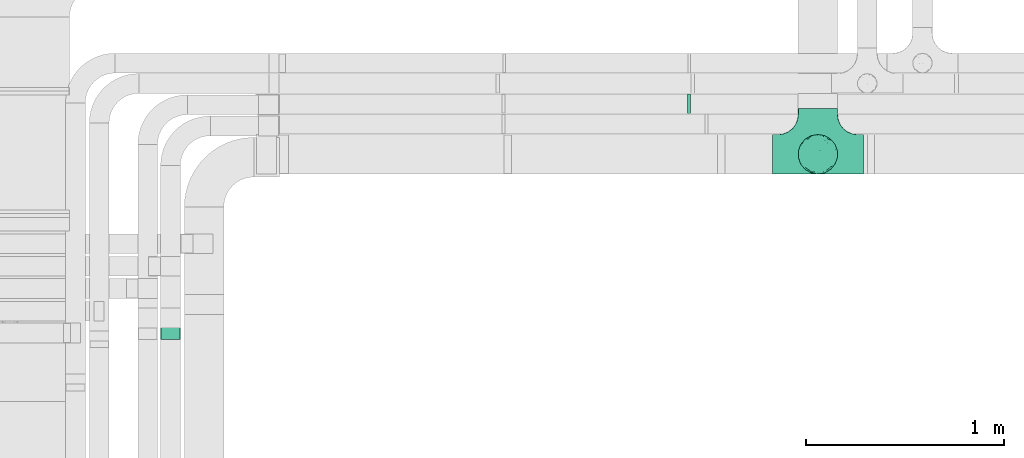
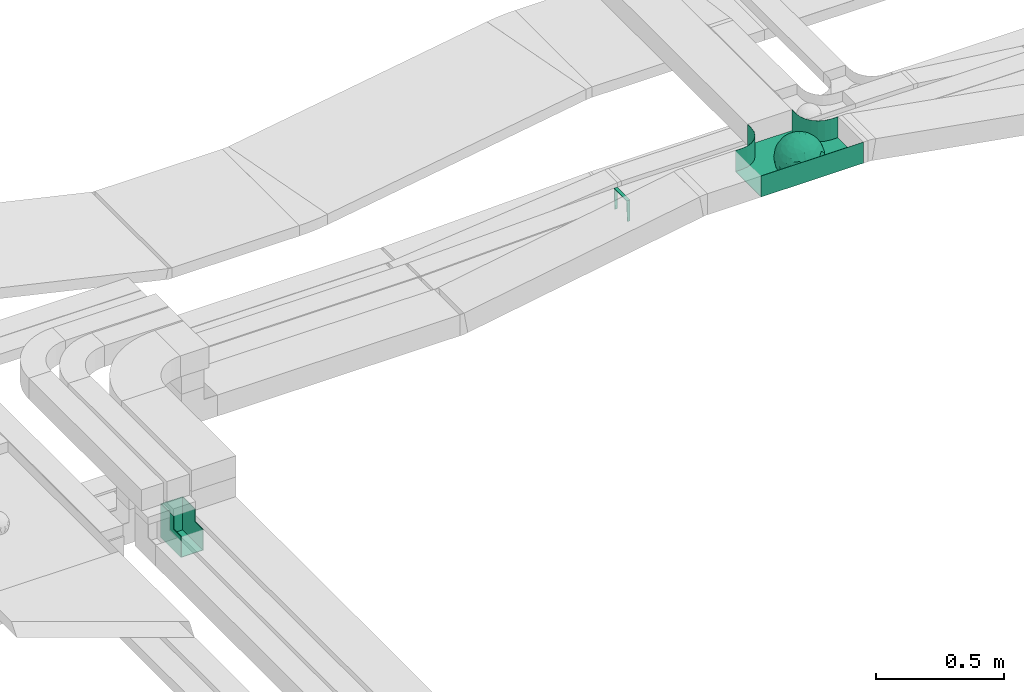
# One storey, part 26 of 28: 3 flow fittings.
"""IFC2X3 building model written with IfcOpenShell, lengths in millimetres."""

from ifc_helpers import new_model, entity, si_unit, converted_unit, derived_unit, direction, frame, origin, place, context, subcontext, project, spatial, faceted_brep, source, transform, mapped, material, material_list, type_object, type_shapes, element, save


model = new_model("IFC2X3")

# Units and contexts
model_context = context("Model", 3, precision=0.01, world=origin(), true_north=direction((6.12303176911189e-17, 1.0)))
body_context = subcontext(model_context, "Body", "Model", "MODEL_VIEW")
ifc_project = project(units=[si_unit("LENGTHUNIT", "METRE", prefix="MILLI"), si_unit("AREAUNIT", "SQUARE_METRE"), si_unit("VOLUMEUNIT", "CUBIC_METRE"), converted_unit("PLANEANGLEUNIT", "DEGREE", entity("IfcRatioMeasure", 0.0174532925199433), si_unit("PLANEANGLEUNIT", "RADIAN"), dimensions=[0, 0, 0, 0, 0, 0, 0]), si_unit("MASSUNIT", "GRAM", prefix="KILO"), derived_unit("MASSDENSITYUNIT", [(si_unit("MASSUNIT", "GRAM", prefix="KILO"), 1), (si_unit("LENGTHUNIT", "METRE"), -3)]), derived_unit("MOMENTOFINERTIAUNIT", [(si_unit("LENGTHUNIT", "METRE"), 4)]), si_unit("TIMEUNIT", "SECOND"), si_unit("FREQUENCYUNIT", "HERTZ"), si_unit("THERMODYNAMICTEMPERATUREUNIT", "DEGREE_CELSIUS"), derived_unit("THERMALTRANSMITTANCEUNIT", [(si_unit("MASSUNIT", "GRAM", prefix="KILO"), 1), (si_unit("THERMODYNAMICTEMPERATUREUNIT", "KELVIN"), -1), (si_unit("TIMEUNIT", "SECOND"), -3)]), derived_unit("VOLUMETRICFLOWRATEUNIT", [(si_unit("LENGTHUNIT", "METRE"), 3), (si_unit("TIMEUNIT", "SECOND"), -1)]), derived_unit("MASSFLOWRATEUNIT", [(si_unit("MASSUNIT", "GRAM", prefix="KILO"), 1), (si_unit("TIMEUNIT", "SECOND"), -1)]), derived_unit("ROTATIONALFREQUENCYUNIT", [(si_unit("TIMEUNIT", "SECOND"), -1)]), si_unit("ELECTRICCURRENTUNIT", "AMPERE"), si_unit("ELECTRICVOLTAGEUNIT", "VOLT"), si_unit("POWERUNIT", "WATT"), si_unit("FORCEUNIT", "NEWTON", prefix="KILO"), si_unit("ILLUMINANCEUNIT", "LUX"), si_unit("LUMINOUSFLUXUNIT", "LUMEN"), si_unit("LUMINOUSINTENSITYUNIT", "CANDELA"), derived_unit("USERDEFINED", [(si_unit("MASSUNIT", "GRAM", prefix="KILO"), -1), (si_unit("LENGTHUNIT", "METRE"), -2), (si_unit("TIMEUNIT", "SECOND"), 3), (si_unit("LUMINOUSFLUXUNIT", "LUMEN"), 1)]), derived_unit("LINEARVELOCITYUNIT", [(si_unit("LENGTHUNIT", "METRE"), 1), (si_unit("TIMEUNIT", "SECOND"), -1)]), si_unit("PRESSUREUNIT", "PASCAL"), derived_unit("USERDEFINED", [(si_unit("LENGTHUNIT", "METRE"), -2), (si_unit("MASSUNIT", "GRAM", prefix="KILO"), 1), (si_unit("TIMEUNIT", "SECOND"), -2)]), derived_unit("LINEARFORCEUNIT", [(si_unit("MASSUNIT", "GRAM", prefix="KILO"), 1), (si_unit("LENGTHUNIT", "METRE"), 1), (si_unit("TIMEUNIT", "SECOND"), -2), (si_unit("LENGTHUNIT", "METRE"), -1)]), derived_unit("PLANARFORCEUNIT", [(si_unit("MASSUNIT", "GRAM", prefix="KILO"), 1), (si_unit("LENGTHUNIT", "METRE"), 1), (si_unit("TIMEUNIT", "SECOND"), -2), (si_unit("LENGTHUNIT", "METRE"), -2)])], contexts=[model_context])

# Site, building, storey
site_placement = place(None, origin())
site = spatial("IfcSite", under=ifc_project, at=site_placement, CompositionType="ELEMENT")
building_placement = place(site_placement, origin())
building = spatial("IfcBuilding", under=site, at=building_placement, CompositionType="ELEMENT")
storey_placement = place(building_placement, frame((0.0, 0.0, 4200.0)))
storey = spatial("IfcBuildingStorey", under=building, at=storey_placement, CompositionType="ELEMENT", Elevation=4200.0)

# Flow fittings
ifc_material_1 = material()
ifc_material_2 = material()
ifc_material_list = material_list([ifc_material_1, ifc_material_2])
cable_carrier_fitting_type_1 = type_object("IfcCableCarrierFittingType", PredefinedType="NOTDEFINED", material=ifc_material_1)
shared_shape_1 = source(origin(), body_context, "Body", "Brep", [
    faceted_brep([(76.48, -37.8, -52.17), (89.29, -26.17, -36.65), (85.27, -46.63, -23.54), (-17.29, -34.78, -92.15), (0.0, -44.16, -89.72), (-24.64, -51.58, -82.05), (76.33, -15.08, -62.82), (55.58, -29.55, -77.71), (-17.1, 96.98, 0.0), (-18.67, 88.89, -41.84), (-33.9, 89.53, -28.9), (-45.46, -10.48, -88.45), (-19.82, 5.04, -97.89), (-23.66, -16.13, -95.81), (92.54, 33.68, 0.0), (85.28, 45.77, -25.16), (86.6, 50.0, 0.0), (49.24, -85.29, 0.0), (62.2, -72.19, -30.32), (64.28, -76.6, 0.0), (97.17, -8.72, -21.95), (90.76, 0.0, -41.98), (96.14, 14.4, -23.44), (98.48, 17.36, 0.0), (98.48, 0.0, 0.0), (79.01, 8.48, -60.71), (76.48, 37.8, -52.17), (87.7, 23.44, -41.95), (29.16, -37.6, -87.95), (20.3, -63.77, -74.31), (-69.62, 53.19, -48.2), (-47.21, 56.75, -67.46), (-61.6, 43.47, -65.69), (29.45, 71.32, -63.61), (47.21, 56.75, -67.46), (30.04, 49.65, -81.44), (-49.67, -77.09, -39.87), (-34.2, -93.97, 0.0), (-49.24, -85.29, 0.0), (61.4, 65.14, -44.57), (74.68, 59.14, -30.41), (61.95, 44.54, -64.64), (28.77, -89.42, -34.29), (34.2, -93.97, 0.0), (25.65, -95.48, 0.0), (17.1, -96.98, 0.0), (-64.28, -76.6, 0.0), (-75.44, -63.3, 0.0), (-74.75, -61.55, -24.99), (7.5, -83.69, -54.22), (36.49, -70.37, -60.97), (-76.48, -37.8, -52.17), (-87.07, -22.49, -43.74), (-79.06, -6.54, -60.88), (63.53, 0.0, -77.22), (-63.53, 0.0, -77.22), (-81.93, 16.04, -55.05), (-98.48, -17.36, 0.0), (-95.57, -17.05, -24.0), (-92.54, -33.68, 0.0), (65.86, 23.41, -71.51), (-19.3, 70.27, -68.49), (-44.33, 79.42, -41.56), (-76.48, 37.8, -52.17), (-45.05, 37.36, -81.09), (-67.2, 22.41, -70.59), (45.89, 15.54, -87.48), (-67.14, -22.46, -70.63), (-97.69, 5.09, -20.78), (-90.76, 0.0, -41.98), (-92.54, 33.68, 0.0), (-92.15, 27.2, -27.72), (28.87, 87.52, -38.83), (7.5, 83.69, -54.22), (1.23, 95.73, -28.9), (3.52, -95.84, -28.34), (-8.55, -98.49, 0.0), (-12.28, -96.15, -24.6), (75.44, 63.3, 0.0), (64.28, 76.6, 0.0), (75.44, -63.3, 0.0), (86.6, -50.0, 0.0), (-75.44, 63.3, 0.0), (-84.89, 46.81, -24.54), (-86.6, 50.0, 0.0), (-65.62, -61.39, -43.88), (-47.21, -56.75, -67.46), (-85.24, -44.68, -27.17), (46.02, 37.17, -80.63), (-63.18, 67.68, -37.79), (-7.15, -67.62, -73.33), (31.54, -5.3, -94.75), (9.85, -20.5, -97.38), (0.0, 13.3, -99.11), (49.35, -11.18, -86.25), (92.54, -33.68, 0.0), (98.48, -17.36, 0.0), (49.24, 85.29, 0.0), (46.4, 79.11, -39.86), (34.2, 93.97, 0.0), (-53.11, 15.12, -83.37), (64.53, -54.17, -53.86), (47.21, -56.75, -67.46), (22.89, 27.57, -93.36), (74.68, -59.14, -30.41), (46.4, -79.11, -39.86), (-15.74, 23.19, -95.99), (2.81, 33.98, -94.01), (9.21, 52.39, -84.68), (9.73, 69.75, -71.0), (17.1, 96.98, 0.0), (-5.62, -90.16, -42.88), (0.0, -100.0, 0.0), (-25.13, -93.37, -25.51), (-25.95, -84.88, -46.06), (-17.1, -96.98, 0.0), (-10.24, -80.78, -58.05), (-31.24, -69.76, -64.48), (-42.19, -33.64, -84.2), (-35.78, 18.55, -91.52), (-61.62, -43.52, -65.64), (-17.34, 40.89, -89.6), (-29.1, 55.69, -77.79), (-10.66, 57.03, -81.45), (-59.77, -75.57, -26.75), (-86.6, -50.0, 0.0), (-98.48, 0.0, 0.0), (-98.48, 17.36, 0.0), (-74.77, 60.7, -26.92), (-64.28, 76.6, 0.0), (-49.24, 85.29, 0.0), (-34.2, 93.97, 0.0), (0.0, 100.0, 0.0), (-76.48, -37.8, 52.17), (-89.29, -26.17, 36.65), (-85.27, -46.63, 23.54), (17.29, -34.78, 92.15), (0.0, -44.16, 89.72), (24.64, -51.58, 82.05), (-76.33, -15.08, 62.82), (-55.58, -29.55, 77.71), (18.67, 88.89, 41.84), (33.9, 89.53, 28.9), (17.34, 40.89, 89.6), (15.74, 23.19, 95.99), (35.78, 18.55, 91.52), (-85.28, 45.77, 25.16), (-62.2, -72.19, 30.32), (-97.17, -8.72, 21.95), (-96.14, 14.4, 23.44), (-79.01, 8.48, 60.71), (-76.48, 37.8, 52.17), (-87.7, 23.44, 41.95), (-29.16, -37.6, 87.95), (-20.3, -63.77, 74.31), (69.62, 53.19, 48.2), (47.21, 56.75, 67.46), (61.6, 43.47, 65.69), (-61.4, 65.14, 44.57), (49.27, -77.35, 39.88), (-74.68, 59.14, 30.41), (-61.95, 44.54, 64.64), (-7.5, -83.69, 54.22), (-36.49, -70.37, 60.97), (-28.77, -89.42, 34.29), (74.74, -61.65, 24.74), (3.0, -95.52, 29.45), (-13.47, -92.75, 34.88), (76.48, -37.8, 52.17), (87.07, -22.49, 43.74), (79.06, -6.54, 60.88), (-63.53, 0.0, 77.22), (63.53, 0.0, 77.22), (81.93, 16.04, 55.05), (95.57, -17.05, 24.0), (-65.86, 23.41, 71.51), (19.3, 70.27, 68.49), (44.33, 79.42, 41.56), (76.48, 37.8, 52.17), (45.05, 37.36, 81.09), (67.2, 22.41, 70.59), (-45.89, 15.54, 87.48), (67.14, -22.46, 70.63), (97.69, 5.09, 20.78), (90.76, 0.0, 41.98), (92.15, 27.2, 27.72), (-28.87, 87.52, 38.83), (-7.5, 83.69, 54.22), (-1.23, 95.73, 28.9), (7.15, -67.62, 73.33), (30.04, -71.02, 63.66), (-90.76, 0.0, 41.98), (84.89, 46.81, 24.54), (65.66, -61.85, 43.17), (47.21, -56.75, 67.46), (85.24, -44.68, 27.17), (-30.04, 49.65, 81.44), (-47.21, 56.75, 67.46), (-46.02, 37.17, 80.63), (63.18, 67.68, 37.79), (-31.54, -5.3, 94.75), (-9.85, -20.5, 97.38), (0.0, 13.3, 99.11), (-49.35, -11.18, 86.25), (-46.4, 79.11, 39.86), (-29.45, 71.32, 63.61), (24.31, -93.79, 24.74), (-64.53, -54.17, 53.86), (-47.21, -56.75, 67.46), (-22.89, 27.57, 93.36), (-46.4, -79.11, 39.86), (-74.68, -59.14, 30.41), (19.82, 5.04, 97.89), (-2.81, 33.98, 94.01), (-9.21, 52.39, 84.68), (-9.73, 69.75, 71.0), (9.65, -80.54, 58.49), (23.47, -86.31, 44.72), (35.11, -89.62, 27.11), (42.19, -33.64, 84.2), (23.66, -16.13, 95.81), (45.46, -10.48, 88.45), (61.62, -43.52, 65.64), (29.1, 55.69, 77.79), (10.66, 57.03, 81.45), (59.35, -75.82, 26.99), (74.77, 60.7, 26.92), (53.11, 15.12, 83.37)], [[[0, 1, 2]], [[3, 4, 5]], [[6, 0, 7]], [[8, 9, 10]], [[11, 12, 13]], [[14, 15, 16]], [[17, 18, 19]], [[20, 21, 22]], [[22, 23, 24]], [[25, 26, 27]], [[4, 28, 29]], [[30, 31, 32]], [[33, 34, 35]], [[36, 37, 38]], [[39, 40, 41]], [[42, 43, 44, 45]], [[46, 47, 48]], [[49, 50, 42]], [[51, 52, 53]], [[54, 25, 6]], [[55, 53, 56]], [[57, 58, 59]], [[26, 25, 60]], [[61, 31, 62]], [[32, 63, 30]], [[64, 65, 32]], [[54, 66, 60]], [[53, 67, 51]], [[58, 68, 69]], [[68, 70, 71]], [[72, 73, 74]], [[75, 76, 77]], [[6, 7, 54]], [[24, 20, 22]], [[78, 40, 79]], [[15, 26, 40]], [[1, 21, 20]], [[80, 2, 81]], [[63, 56, 71]], [[82, 83, 84]], [[36, 85, 86]], [[87, 58, 52]], [[35, 34, 88]], [[62, 31, 89]], [[42, 75, 49]], [[4, 29, 90]], [[91, 92, 93]], [[7, 94, 54]], [[6, 1, 0]], [[95, 81, 2]], [[24, 96, 20]], [[1, 20, 95]], [[1, 95, 2]], [[27, 22, 21]], [[15, 14, 22]], [[25, 27, 21]], [[15, 78, 16]], [[41, 40, 26]], [[40, 78, 15]], [[39, 97, 79]], [[97, 98, 99]], [[40, 39, 79]], [[33, 73, 72]], [[21, 1, 6]], [[25, 54, 60]], [[64, 100, 65]], [[26, 15, 27]], [[6, 25, 21]], [[0, 101, 7]], [[102, 28, 7]], [[92, 91, 28]], [[94, 28, 91]], [[88, 34, 41]], [[54, 94, 66]], [[41, 26, 60]], [[103, 91, 93]], [[88, 41, 60]], [[20, 96, 95]], [[101, 18, 102]], [[104, 80, 19]], [[101, 0, 104]], [[18, 105, 102]], [[43, 42, 105]], [[17, 43, 105]], [[29, 28, 102]], [[28, 4, 92]], [[105, 50, 102]], [[90, 29, 49]], [[88, 60, 66]], [[41, 34, 39]], [[34, 98, 39]], [[97, 39, 98]], [[103, 66, 91]], [[88, 66, 103]], [[12, 106, 93]], [[33, 98, 34]], [[107, 103, 93]], [[35, 103, 108]], [[103, 35, 88]], [[33, 109, 73]], [[109, 35, 108]], [[110, 72, 74]], [[72, 110, 99]], [[98, 33, 72]], [[99, 98, 72]], [[80, 104, 2]], [[0, 2, 104]], [[101, 104, 18]], [[7, 101, 102]], [[19, 18, 104]], [[105, 18, 17]], [[77, 111, 75]], [[75, 45, 112]], [[113, 114, 111]], [[115, 77, 76]], [[36, 114, 37]], [[90, 5, 4]], [[75, 42, 45]], [[50, 49, 29]], [[49, 116, 90]], [[5, 117, 86]], [[90, 116, 117]], [[118, 13, 3]], [[118, 5, 86]], [[11, 119, 12]], [[67, 120, 51]], [[11, 13, 118]], [[65, 55, 56]], [[121, 122, 123]], [[90, 117, 5]], [[51, 120, 85]], [[117, 36, 86]], [[36, 117, 114]], [[46, 48, 124]], [[38, 124, 36]], [[85, 124, 48]], [[87, 125, 59]], [[125, 87, 47]], [[48, 51, 85]], [[68, 57, 126, 127]], [[59, 58, 87]], [[58, 69, 52]], [[53, 52, 69]], [[87, 52, 51]], [[56, 53, 69]], [[53, 55, 67]], [[71, 56, 69]], [[56, 63, 65]], [[71, 69, 68]], [[128, 129, 89]], [[11, 67, 55]], [[120, 118, 86]], [[32, 65, 63]], [[100, 55, 65]], [[118, 120, 67]], [[85, 120, 86]], [[129, 128, 82]], [[64, 32, 31]], [[62, 130, 131]], [[130, 62, 89]], [[9, 73, 61]], [[10, 62, 131]], [[109, 61, 73]], [[73, 9, 74]], [[64, 121, 119]], [[122, 61, 123]], [[64, 119, 100]], [[64, 31, 122]], [[107, 108, 103]], [[47, 87, 48]], [[51, 48, 87]], [[57, 68, 58]], [[64, 122, 121]], [[89, 129, 130]], [[67, 11, 118]], [[11, 55, 100]], [[82, 128, 83]], [[30, 128, 89]], [[83, 63, 71]], [[63, 83, 128]], [[84, 83, 71]], [[10, 61, 62]], [[74, 8, 132]], [[8, 74, 9]], [[110, 74, 132]], [[3, 92, 4]], [[92, 13, 12]], [[22, 27, 15]], [[14, 23, 22]], [[11, 100, 119]], [[128, 30, 63]], [[31, 30, 89]], [[28, 94, 7]], [[66, 94, 91]], [[42, 50, 105]], [[29, 102, 50]], [[106, 107, 93]], [[123, 107, 121]], [[35, 109, 33]], [[109, 108, 123]], [[75, 112, 76]], [[113, 77, 115]], [[114, 116, 111]], [[115, 37, 113]], [[37, 114, 113]], [[49, 75, 111]], [[117, 116, 114]], [[111, 77, 113]], [[49, 111, 116]], [[118, 3, 5]], [[92, 3, 13]], [[106, 119, 121]], [[92, 12, 93]], [[119, 106, 12]], [[107, 106, 121]], [[46, 124, 38]], [[85, 36, 124]], [[70, 68, 127]], [[70, 84, 71]], [[31, 61, 122]], [[109, 123, 61]], [[107, 123, 108]], [[8, 10, 131]], [[61, 10, 9]], [[133, 134, 135]], [[136, 137, 138]], [[139, 133, 140]], [[110, 141, 142]], [[143, 144, 145]], [[70, 146, 84]], [[38, 147, 46]], [[126, 57, 148]], [[149, 127, 126]], [[150, 151, 152]], [[137, 153, 154]], [[155, 156, 157]], [[130, 129, 158]], [[159, 43, 17]], [[158, 160, 161]], [[162, 163, 164]], [[19, 80, 165]], [[166, 167, 115]], [[168, 169, 170]], [[171, 150, 139]], [[172, 170, 173]], [[96, 174, 95]], [[151, 150, 175]], [[176, 156, 177]], [[157, 178, 155]], [[179, 180, 157]], [[171, 181, 175]], [[170, 182, 168]], [[174, 183, 184]], [[185, 23, 14, 16]], [[186, 187, 188]], [[138, 189, 190]], [[139, 140, 171]], [[126, 148, 149]], [[82, 160, 129]], [[146, 151, 160]], [[134, 191, 148]], [[47, 135, 125]], [[178, 173, 185]], [[78, 192, 16]], [[159, 193, 194]], [[195, 174, 169]], [[196, 197, 198]], [[177, 156, 199]], [[166, 112, 45]], [[154, 189, 137]], [[200, 201, 202]], [[140, 203, 171]], [[191, 149, 148]], [[59, 125, 135]], [[133, 139, 134]], [[134, 148, 59]], [[134, 59, 135]], [[152, 149, 191]], [[146, 70, 149]], [[150, 152, 191]], [[146, 82, 84]], [[161, 160, 151]], [[160, 82, 146]], [[204, 131, 130]], [[186, 205, 187]], [[160, 158, 129]], [[197, 196, 205]], [[191, 134, 139]], [[150, 171, 175]], [[45, 206, 166]], [[151, 146, 152]], [[139, 150, 191]], [[133, 207, 140]], [[208, 153, 140]], [[201, 200, 153]], [[203, 153, 200]], [[198, 197, 161]], [[171, 203, 181]], [[161, 151, 175]], [[209, 200, 202]], [[198, 161, 175]], [[148, 57, 59]], [[38, 37, 210]], [[211, 47, 46]], [[207, 133, 211]], [[147, 210, 208]], [[210, 37, 164]], [[208, 207, 147]], [[154, 153, 208]], [[153, 137, 201]], [[210, 163, 208]], [[189, 154, 162]], [[198, 175, 181]], [[161, 197, 158]], [[197, 204, 158]], [[130, 158, 204]], [[209, 181, 200]], [[198, 181, 209]], [[212, 144, 202]], [[205, 204, 197]], [[213, 209, 202]], [[196, 209, 214]], [[209, 196, 198]], [[205, 215, 187]], [[215, 196, 214]], [[8, 186, 188]], [[186, 8, 131]], [[204, 205, 186]], [[131, 204, 186]], [[47, 211, 135]], [[133, 135, 211]], [[207, 211, 147]], [[140, 207, 208]], [[46, 147, 211]], [[210, 147, 38]], [[166, 115, 76, 112]], [[115, 164, 37]], [[163, 162, 154]], [[216, 166, 217]], [[138, 137, 189]], [[162, 216, 189]], [[218, 44, 43]], [[44, 218, 206]], [[189, 216, 190]], [[219, 220, 136]], [[219, 138, 194]], [[221, 145, 212]], [[182, 222, 168]], [[221, 220, 219]], [[180, 172, 173]], [[143, 223, 224]], [[168, 222, 193]], [[194, 138, 190]], [[190, 159, 194]], [[190, 217, 218]], [[19, 165, 225]], [[17, 225, 159]], [[193, 225, 165]], [[195, 81, 95]], [[81, 195, 80]], [[165, 168, 193]], [[183, 96, 24, 23]], [[95, 174, 195]], [[174, 184, 169]], [[170, 169, 184]], [[195, 169, 168]], [[173, 170, 184]], [[170, 172, 182]], [[185, 173, 184]], [[173, 178, 180]], [[185, 184, 183]], [[226, 79, 199]], [[221, 182, 172]], [[222, 219, 194]], [[157, 180, 178]], [[227, 172, 180]], [[219, 222, 182]], [[193, 222, 194]], [[79, 226, 78]], [[179, 157, 156]], [[177, 97, 99]], [[97, 177, 199]], [[141, 187, 176]], [[142, 177, 99]], [[215, 176, 187]], [[187, 141, 188]], [[179, 143, 145]], [[223, 176, 224]], [[179, 145, 227]], [[179, 156, 223]], [[213, 214, 209]], [[96, 183, 174]], [[185, 183, 23]], [[80, 195, 165]], [[168, 165, 195]], [[199, 79, 97]], [[182, 221, 219]], [[221, 172, 227]], [[78, 226, 192]], [[155, 226, 199]], [[192, 178, 185]], [[178, 192, 226]], [[16, 192, 185]], [[142, 176, 177]], [[188, 110, 132]], [[110, 188, 141]], [[8, 188, 132]], [[136, 201, 137]], [[201, 220, 212]], [[149, 152, 146]], [[70, 127, 149]], [[167, 162, 164]], [[179, 227, 180]], [[221, 227, 145]], [[226, 155, 178]], [[156, 155, 199]], [[153, 203, 140]], [[181, 203, 200]], [[164, 163, 210]], [[154, 208, 163]], [[144, 213, 202]], [[224, 213, 143]], [[196, 215, 205]], [[215, 214, 224]], [[166, 216, 162]], [[190, 216, 217]], [[218, 217, 206]], [[43, 159, 218]], [[190, 218, 159]], [[166, 206, 217]], [[44, 206, 45]], [[219, 136, 138]], [[201, 136, 220]], [[201, 212, 202]], [[221, 212, 220]], [[145, 144, 212]], [[213, 144, 143]], [[19, 225, 17]], [[193, 159, 225]], [[179, 223, 143]], [[156, 176, 223]], [[215, 224, 176]], [[213, 224, 214]], [[110, 142, 99]], [[176, 142, 141]], [[115, 167, 164]], [[166, 162, 167]]]),
    faceted_brep([(-103.41, -174.12, 50.0), (-100.0, -200.0, 50.0), (-100.0, -230.0, 50.0), (-99.2, -230.0, 50.0), (-99.2, -200.0, 50.0), (-102.63, -173.91, 50.0), (-112.7, -149.6, 50.0), (-128.72, -128.72, 50.0), (-149.6, -112.7, 50.0), (-173.91, -102.63, 50.0), (-200.0, -99.2, 50.0), (-230.0, -99.2, 50.0), (-230.0, -100.0, 50.0), (-200.0, -100.0, 50.0), (-174.12, -103.41, 50.0), (-150.0, -113.4, 50.0), (-129.29, -129.29, 50.0), (-113.4, -150.0, 50.0), (230.0, -100.0, 50.0), (230.0, -99.2, 50.0), (200.0, -99.2, 50.0), (173.91, -102.63, 50.0), (149.6, -112.7, 50.0), (128.72, -128.72, 50.0), (112.7, -149.6, 50.0), (102.63, -173.91, 50.0), (99.2, -200.0, 50.0), (99.2, -230.0, 50.0), (100.0, -230.0, 50.0), (100.0, -200.0, 50.0), (103.41, -174.12, 50.0), (113.4, -150.0, 50.0), (129.29, -129.29, 50.0), (150.0, -113.4, 50.0), (174.12, -103.41, 50.0), (200.0, -100.0, 50.0), (230.0, 99.2, 50.0), (230.0, 100.0, 50.0), (-230.0, 100.0, 50.0), (-230.0, 99.2, 50.0), (-230.0, -100.0, -50.0), (-230.0, 100.0, -50.0), (230.0, 100.0, -50.0), (230.0, -100.0, -50.0), (200.0, -100.0, -50.0), (174.12, -103.41, -50.0), (150.0, -113.4, -50.0), (129.29, -129.29, -50.0), (113.4, -150.0, -50.0), (103.41, -174.12, -50.0), (100.0, -200.0, -50.0), (100.0, -230.0, -50.0), (-100.0, -230.0, -50.0), (-100.0, -200.0, -50.0), (-103.41, -174.12, -50.0), (-113.4, -150.0, -50.0), (-129.29, -129.29, -50.0), (-150.0, -113.4, -50.0), (-174.12, -103.41, -50.0), (-200.0, -100.0, -50.0), (-100.0, -200.0, -49.2), (99.2, -230.0, -49.2), (-99.2, -230.0, -49.2), (-99.2, -200.0, -49.2), (-200.0, -99.2, -49.2), (-230.0, -99.2, -49.2), (230.0, -99.2, -49.2), (200.0, -99.2, -49.2), (-230.0, 99.2, -49.2), (-200.0, -100.0, -49.2), (200.0, -100.0, -49.2), (230.0, 99.2, -49.2), (99.2, -200.0, -49.2), (100.0, -200.0, -49.2), (-173.91, -102.63, -49.2), (-149.6, -112.7, -49.2), (-128.72, -128.72, -49.2), (-112.7, -149.6, -49.2), (-102.63, -173.91, -49.2), (102.63, -173.91, -49.2), (112.7, -149.6, -49.2), (128.72, -128.72, -49.2), (149.6, -112.7, -49.2), (173.91, -102.63, -49.2)], [[[0, 1, 2, 3, 4, 5, 6, 7, 8, 9, 10, 11, 12, 13, 14, 15, 16, 17]], [[18, 19, 20, 21, 22, 23, 24, 25, 26, 27, 28, 29, 30, 31, 32, 33, 34, 35]], [[36, 37, 38, 39]], [[40, 41, 42, 43, 44, 45, 46, 47, 48, 49, 50, 51, 52, 53, 54, 55, 56, 57, 58, 59]], [[2, 1, 60, 53, 52]], [[3, 2, 52, 51, 28, 27, 61, 62]], [[4, 3, 62, 63]], [[11, 10, 64, 65]], [[20, 19, 66, 67]], [[39, 38, 41, 40, 12, 11, 65, 68]], [[13, 12, 40, 59, 69]], [[18, 35, 70, 44, 43]], [[19, 18, 43, 42, 37, 36, 71, 66]], [[27, 26, 72, 61]], [[29, 28, 51, 50, 73]], [[38, 37, 42, 41]], [[36, 39, 68, 71]], [[68, 65, 64, 74, 75, 76, 77, 78, 63, 62, 61, 72, 79, 80, 81, 82, 83, 67, 66, 71]], [[14, 13, 69, 59, 58]], [[15, 14, 58, 57]], [[57, 56, 16, 15]], [[17, 16, 56, 55]], [[0, 17, 55, 54]], [[1, 0, 54, 53, 60]], [[5, 78, 77, 6]], [[6, 77, 76, 7]], [[63, 78, 5, 4]], [[8, 75, 74, 9]], [[9, 74, 64, 10]], [[7, 76, 75, 8]], [[21, 83, 82, 22]], [[22, 82, 81, 23]], [[67, 83, 21, 20]], [[24, 80, 79, 25]], [[25, 79, 72, 26]], [[23, 81, 80, 24]], [[30, 29, 73, 50, 49]], [[31, 30, 49, 48]], [[32, 31, 48, 47]], [[34, 33, 46, 45]], [[34, 45, 44, 70, 35]], [[46, 33, 32, 47]]]),
])
type_shapes(cable_carrier_fitting_type_1, [shared_shape_1])
flow_fitting_1_placement = place(storey_placement, frame((14583.54, 11543.79, 2954.06), z_axis=(0.0, 0.0, 1.0), x_axis=(-1.0, 0.0, 0.0)))
element("IfcFlowFitting", 1, at=flow_fitting_1_placement, inside=storey, type_object=cable_carrier_fitting_type_1, material=ifc_material_list, Name="470_DKC_S5_T", context=body_context, shape_type="MappedRepresentation", body=[
    mapped(shared_shape_1, transform((0.0, 0.0, 0.0), scale=1.0)),
])
cable_carrier_fitting_type_2 = type_object("IfcCableCarrierFittingType", PredefinedType="NOTDEFINED", material=ifc_material_2)
shared_shape_2 = source(origin(), body_context, "Body", "Brep", [
    faceted_brep([(-6.77, -50.0, 50.0), (-6.77, 50.0, 50.0), (-6.77, 50.0, 47.46), (-6.77, -47.46, 47.46), (-6.77, -47.46, -47.46), (-6.77, 50.0, -47.46), (-6.77, 50.0, -50.0), (-6.77, -50.0, -50.0), (8.46, -49.74, 50.0), (8.46, -49.74, -50.0), (5.08, 50.2, -50.0), (5.08, 50.2, -47.46), (8.37, -47.2, -47.46), (8.37, -47.2, 47.46), (5.08, 50.2, 47.46), (5.08, 50.2, 50.0), (0.85, -50.0, 50.0), (-0.85, 50.0, 50.0), (-0.85, 50.0, 47.46), (0.8, -47.46, 47.46), (0.8, -47.46, -47.46), (-0.85, 50.0, -47.46), (-0.85, 50.0, -50.0), (0.85, -50.0, -50.0)], [[[0, 1, 2, 3, 4, 5, 6, 7]], [[8, 9, 10, 11, 12, 13, 14, 15]], [[1, 0, 16, 8, 15, 17]], [[2, 1, 17, 18]], [[3, 2, 18, 14, 13, 19]], [[4, 3, 19, 20]], [[5, 4, 20, 12, 11, 21]], [[6, 5, 21, 22]], [[7, 6, 22, 10, 9, 23]], [[0, 7, 23, 16]], [[18, 17, 15, 14]], [[20, 19, 13, 12]], [[22, 21, 11, 10]], [[16, 23, 9, 8]]]),
])
type_shapes(cable_carrier_fitting_type_2, [shared_shape_2])
flow_fitting_2_placement = place(storey_placement, frame((13934.02, 11798.96, 2800.18), z_axis=(0.0, 1.0, 0.0), x_axis=(0.999429384266034, 0.0, 0.0337772980804678)))
element("IfcFlowFitting", 2, at=flow_fitting_2_placement, inside=storey, type_object=cable_carrier_fitting_type_2, material=ifc_material_2, context=body_context, shape_type="MappedRepresentation", body=[
    mapped(shared_shape_2, transform((0.0, 0.0, 0.0), scale=1.0)),
])
cable_carrier_fitting_type_3 = type_object("IfcCableCarrierFittingType", PredefinedType="NOTDEFINED", material=ifc_material_2)
shared_shape_3 = source(origin(), body_context, "Body", "Brep", [
    faceted_brep([(-110.01, -50.0, 50.0), (-110.01, 50.0, 50.0), (-110.01, 50.0, 47.46), (-110.01, -47.46, 47.46), (-110.01, -47.46, -47.46), (-110.01, 50.0, -47.46), (-110.01, 50.0, -50.0), (-110.01, -50.0, -50.0), (49.99, 110.02, 50.0), (49.99, 110.02, -50.0), (-50.01, 110.01, -50.0), (-50.01, 110.01, -47.46), (47.45, 110.01, -47.46), (47.45, 110.01, 47.46), (-50.01, 110.01, 47.46), (-50.01, 110.01, 50.0), (50.0, -50.0, 50.0), (-50.0, 50.0, 50.0), (-50.0, 50.0, 47.46), (47.46, -47.46, 47.46), (47.46, -47.46, -47.46), (-50.0, 50.0, -47.46), (-50.0, 50.0, -50.0), (50.0, -50.0, -50.0)], [[[0, 1, 2, 3, 4, 5, 6, 7]], [[8, 9, 10, 11, 12, 13, 14, 15]], [[1, 0, 16, 8, 15, 17]], [[2, 1, 17, 18]], [[3, 2, 18, 14, 13, 19]], [[4, 3, 19, 20]], [[5, 4, 20, 12, 11, 21]], [[6, 5, 21, 22]], [[7, 6, 22, 10, 9, 23]], [[0, 7, 23, 16]], [[18, 17, 15, 14]], [[20, 19, 13, 12]], [[22, 21, 11, 10]], [[16, 23, 9, 8]]]),
])
type_shapes(cable_carrier_fitting_type_3, [shared_shape_3])
flow_fitting_3_placement = place(storey_placement, frame((11313.59, 10717.04, 2829.58), z_axis=(-1.0, 0.0, 0.0), x_axis=(0.0, 0.0, -1.0)))
element("IfcFlowFitting", 3, at=flow_fitting_3_placement, inside=storey, type_object=cable_carrier_fitting_type_3, material=ifc_material_2, context=body_context, shape_type="MappedRepresentation", body=[
    mapped(shared_shape_3, transform((0.0, 0.0, 0.0), scale=1.0)),
])

save(model, "model.ifc")
